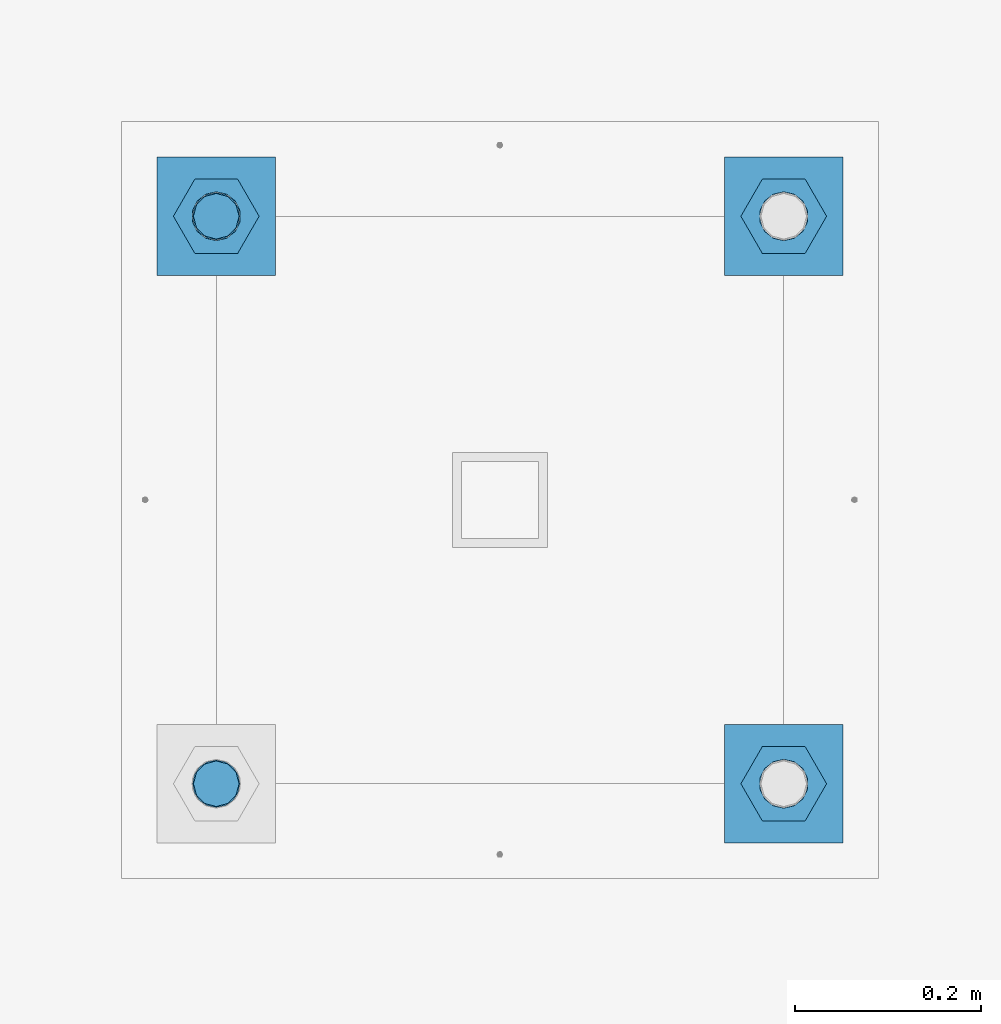
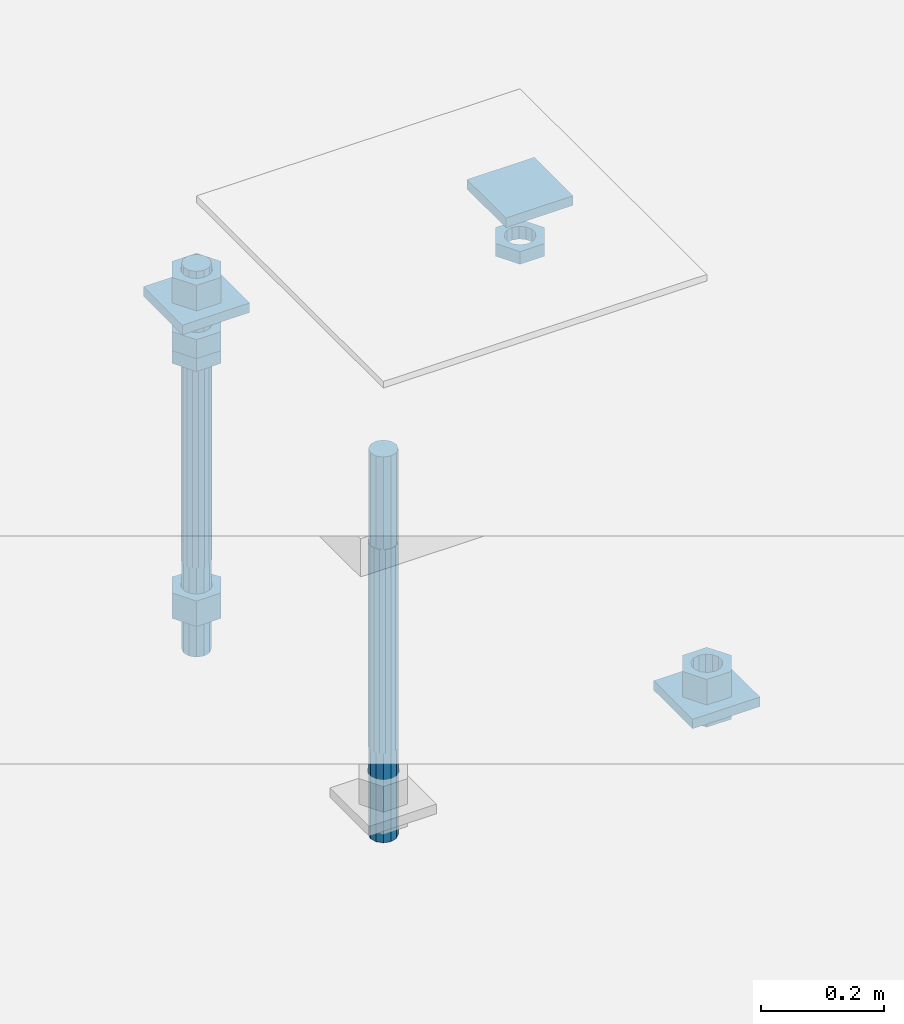
# One storey, part 2707 of 3843: 12 beams, 1 element without a shape of its own.
"""IFC2X3 building model written with IfcOpenShell, lengths in millimetres."""

from ifc_helpers import new_model, si_unit, frame, origin_with_axes, place, context, subcontext, project, spatial, faceted_brep, material, type_object, element, aggregate, save


model = new_model("IFC2X3")

# Units and contexts
model_context = context("Model", 3, precision=1e-05, world=origin_with_axes())
body_context = subcontext(model_context, "Body", "Model", "MODEL_VIEW")
ifc_project = project(units=[si_unit("LENGTHUNIT", "METRE", prefix="MILLI"), si_unit("AREAUNIT", "SQUARE_METRE"), si_unit("VOLUMEUNIT", "CUBIC_METRE"), si_unit("MASSUNIT", "GRAM", prefix="KILO"), si_unit("TIMEUNIT", "SECOND"), si_unit("PLANEANGLEUNIT", "RADIAN"), si_unit("SOLIDANGLEUNIT", "STERADIAN"), si_unit("THERMODYNAMICTEMPERATUREUNIT", "DEGREE_CELSIUS"), si_unit("LUMINOUSINTENSITYUNIT", "LUMEN")], contexts=[model_context])

# Site, building, storey
site_placement = place(None, origin_with_axes())
site = spatial("IfcSite", under=ifc_project, at=site_placement, CompositionType="ELEMENT")
building_placement = place(site_placement, origin_with_axes())
building = spatial("IfcBuilding", under=site, at=building_placement, Name="Undefined", CompositionType="ELEMENT")
storey_placement = place(building_placement, origin_with_axes())
storey = spatial("IfcBuildingStorey", under=building, at=storey_placement, Name="Undefined", CompositionType="ELEMENT", Elevation=0.0)

# Assembly, beams
assembly_placement = place(storey_placement, origin_with_axes())
assembly = element("IfcElementAssembly", 1, at=assembly_placement, inside=storey, Name="TEMPLATE", AssemblyPlace="NOTDEFINED", PredefinedType="RIGID_FRAME")
ifc_material_1 = material(Name="STEEL/A36")
beam_type_1 = type_object("IfcBeamType", PredefinedType="NOTDEFINED")
beam_1_placement = place(assembly_placement, frame((108648.5, 45808.9000015259, 29873.575), z_axis=(1.0, 0.0, 0.0), x_axis=(0.0, 1.0, 0.0)))
beam_1 = element("IfcBeam", 2, at=beam_1_placement, type_object=beam_type_1, material=ifc_material_1, Name="WASHER_PLATE", context=body_context, shape_type="Brep", body=[
    faceted_brep([(0.0, 9.52500000000146, -63.5), (0.0, 9.52500000000146, 63.5), (127.0, 9.52500000000146, 63.5), (127.0, 9.52500000000146, -63.5), (0.0, -9.52500000000146, 63.5), (127.0, -9.52500000000146, 63.5), (0.0, -9.52500000000146, -63.5), (127.0, -9.52500000000146, -63.5)], [[[0, 1, 2, 3]], [[1, 4, 5, 2]], [[4, 6, 7, 5]], [[6, 0, 3, 7]], [[5, 7, 3, 2]], [[6, 4, 1, 0]]]),
])
beam_2_placement = place(assembly_placement, frame((109258.1, 45808.9000015259, 29873.575), z_axis=(1.0, 0.0, 0.0), x_axis=(0.0, 1.0, 0.0)))
beam_2 = element("IfcBeam", 3, at=beam_2_placement, type_object=beam_type_1, material=ifc_material_1, Name="WASHER_PLATE", context=body_context, shape_type="Brep", body=[
    faceted_brep([(0.0, 9.52500000000146, -63.5), (0.0, 9.52500000000146, 63.5), (127.0, 9.52500000000146, 63.5), (127.0, 9.52500000000146, -63.5), (0.0, -9.52500000000146, 63.5), (127.0, -9.52500000000146, 63.5), (0.0, -9.52500000000146, -63.5), (127.0, -9.52500000000146, -63.5)], [[[0, 1, 2, 3]], [[1, 4, 5, 2]], [[4, 6, 7, 5]], [[6, 0, 3, 7]], [[5, 7, 3, 2]], [[6, 4, 1, 0]]]),
])
beam_3_placement = place(assembly_placement, frame((109258.1, 45199.3000015259, 29244.925), z_axis=(1.0, 0.0, 0.0), x_axis=(0.0, 1.0, 0.0)))
beam_3 = element("IfcBeam", 4, at=beam_3_placement, type_object=beam_type_1, material=ifc_material_1, Name="WASHER_PLATE", context=body_context, shape_type="Brep", body=[
    faceted_brep([(0.0, 9.52500000000146, -63.5), (0.0, 9.52500000000146, 63.5), (127.0, 9.52500000000146, 63.5), (127.0, 9.52500000000146, -63.5), (0.0, -9.52500000000146, 63.5), (127.0, -9.52500000000146, 63.5), (0.0, -9.52500000000146, -63.5), (127.0, -9.52500000000146, -63.5)], [[[0, 1, 2, 3]], [[1, 4, 5, 2]], [[4, 6, 7, 5]], [[6, 0, 3, 7]], [[5, 7, 3, 2]], [[6, 4, 1, 0]]]),
])
beam_type_2 = type_object("IfcBeamType", Name="2_HALF_NUT", PredefinedType="NOTDEFINED")
beam_4_placement = place(assembly_placement, frame((108648.5, 45872.4000015259, 29787.85), z_axis=(0.0, 1.0, 0.0), x_axis=(0.0, 0.0, -1.0)))
beam_4 = element("IfcBeam", 5, at=beam_4_placement, type_object=beam_type_2, material=ifc_material_1, Name="NUT", ObjectType="2_HALF_NUT", context=body_context, shape_type="Brep", body=[
    faceted_brep([(0.0, -46.0369987487793, 0.0), (0.0, -23.0184993743896, -39.869213104248), (25.4000000000015, -23.0184993743896, -39.869213104248), (25.4000000000015, -46.0369987487793, 0.0), (0.0, 23.0184993743896, -39.869213104248), (25.4000000000015, 23.0184993743896, -39.869213104248), (0.0, 46.0369987487793, 0.0), (25.4000000000015, 46.0369987487793, 0.0), (0.0, 23.0184993743896, 39.869213104248), (25.4000000000015, 23.0184993743896, 39.869213104248), (0.0, -23.0184993743896, 39.869213104248), (25.4000000000015, -23.0184993743896, 39.869213104248), (0.0, 0.0, 26.1940002441406), (0.0, 11.3650617044477, 23.5999013092805), (25.4000000000015, 11.3650617044477, 23.5999013092805), (25.4000000000015, 0.0, 26.1940002441406), (0.0, 20.4791109456419, 16.3316083006721), (25.4000000000015, 20.4791109456419, 16.3316083006721), (0.0, 25.5370200498292, 5.82867859874386), (25.4000000000015, 25.5370200498292, 5.82867859874386), (0.0, 25.5370200498292, -5.82867859874386), (25.4000000000015, 25.5370200498292, -5.82867859874386), (0.0, 20.4791109456419, -16.3316083006721), (25.4000000000015, 20.4791109456419, -16.3316083006721), (0.0, 11.3650617044477, -23.5999013092805), (25.4000000000015, 11.3650617044477, -23.5999013092805), (0.0, 0.0, -26.1940002441406), (25.4000000000015, 0.0, -26.1940002441406), (0.0, -11.3650617044477, -23.5999013092805), (25.4000000000015, -11.3650617044477, -23.5999013092805), (0.0, -20.4791109456419, -16.3316083006721), (25.4000000000015, -20.4791109456419, -16.3316083006721), (0.0, -25.5370200498292, -5.82867859874386), (25.4000000000015, -25.5370200498292, -5.82867859874386), (0.0, -25.5370200498292, 5.82867859874386), (25.4000000000015, -25.5370200498292, 5.82867859874386), (0.0, -20.4791109456419, 16.3316083006721), (25.4000000000015, -20.4791109456419, 16.3316083006721), (0.0, -11.3650617044477, 23.5999013092805), (25.4000000000015, -11.3650617044477, 23.5999013092805)], [[[0, 1, 2, 3]], [[1, 4, 5, 2]], [[4, 6, 7, 5]], [[6, 8, 9, 7]], [[8, 10, 11, 9]], [[10, 0, 3, 11]], [[12, 13, 14, 15]], [[13, 16, 17, 14]], [[16, 18, 19, 17]], [[18, 20, 21, 19]], [[20, 22, 23, 21]], [[22, 24, 25, 23]], [[24, 26, 27, 25]], [[26, 28, 29, 27]], [[28, 30, 31, 29]], [[30, 32, 33, 31]], [[32, 34, 35, 33]], [[34, 36, 37, 35]], [[36, 38, 39, 37]], [[38, 12, 15, 39]], [[5, 7, 9, 11, 3, 2], [17, 19, 21, 23, 25, 27, 29, 31, 33, 35, 37, 39, 15, 14]], [[10, 8, 6, 4, 1, 0], [38, 36, 34, 32, 30, 28, 26, 24, 22, 20, 18, 16, 13, 12]]]),
])
beam_5_placement = place(assembly_placement, frame((109258.1, 45872.4000015259, 29787.85), z_axis=(0.0, 1.0, 0.0), x_axis=(0.0, 0.0, -1.0)))
beam_5 = element("IfcBeam", 6, at=beam_5_placement, type_object=beam_type_2, material=ifc_material_1, Name="NUT", ObjectType="2_HALF_NUT", context=body_context, shape_type="Brep", body=[
    faceted_brep([(0.0, -46.0369987487793, 0.0), (0.0, -23.0184993743896, -39.869213104248), (25.4000000000015, -23.0184993743896, -39.869213104248), (25.4000000000015, -46.0369987487793, 0.0), (0.0, 23.0184993743896, -39.869213104248), (25.4000000000015, 23.0184993743896, -39.869213104248), (0.0, 46.0369987487793, 0.0), (25.4000000000015, 46.0369987487793, 0.0), (0.0, 23.0184993743896, 39.869213104248), (25.4000000000015, 23.0184993743896, 39.869213104248), (0.0, -23.0184993743896, 39.869213104248), (25.4000000000015, -23.0184993743896, 39.869213104248), (0.0, 0.0, 26.1940002441406), (0.0, 11.3650617044477, 23.5999013092805), (25.4000000000015, 11.3650617044477, 23.5999013092805), (25.4000000000015, 0.0, 26.1940002441406), (0.0, 20.4791109456419, 16.3316083006721), (25.4000000000015, 20.4791109456419, 16.3316083006721), (0.0, 25.5370200498292, 5.82867859874386), (25.4000000000015, 25.5370200498292, 5.82867859874386), (0.0, 25.5370200498292, -5.82867859874386), (25.4000000000015, 25.5370200498292, -5.82867859874386), (0.0, 20.4791109456419, -16.3316083006721), (25.4000000000015, 20.4791109456419, -16.3316083006721), (0.0, 11.3650617044477, -23.5999013092805), (25.4000000000015, 11.3650617044477, -23.5999013092805), (0.0, 0.0, -26.1940002441406), (25.4000000000015, 0.0, -26.1940002441406), (0.0, -11.3650617044477, -23.5999013092805), (25.4000000000015, -11.3650617044477, -23.5999013092805), (0.0, -20.4791109456419, -16.3316083006721), (25.4000000000015, -20.4791109456419, -16.3316083006721), (0.0, -25.5370200498292, -5.82867859874386), (25.4000000000015, -25.5370200498292, -5.82867859874386), (0.0, -25.5370200498292, 5.82867859874386), (25.4000000000015, -25.5370200498292, 5.82867859874386), (0.0, -20.4791109456419, 16.3316083006721), (25.4000000000015, -20.4791109456419, 16.3316083006721), (0.0, -11.3650617044477, 23.5999013092805), (25.4000000000015, -11.3650617044477, 23.5999013092805)], [[[0, 1, 2, 3]], [[1, 4, 5, 2]], [[4, 6, 7, 5]], [[6, 8, 9, 7]], [[8, 10, 11, 9]], [[10, 0, 3, 11]], [[12, 13, 14, 15]], [[13, 16, 17, 14]], [[16, 18, 19, 17]], [[18, 20, 21, 19]], [[20, 22, 23, 21]], [[22, 24, 25, 23]], [[24, 26, 27, 25]], [[26, 28, 29, 27]], [[28, 30, 31, 29]], [[30, 32, 33, 31]], [[32, 34, 35, 33]], [[34, 36, 37, 35]], [[36, 38, 39, 37]], [[38, 12, 15, 39]], [[5, 7, 9, 11, 3, 2], [17, 19, 21, 23, 25, 27, 29, 31, 33, 35, 37, 39, 15, 14]], [[10, 8, 6, 4, 1, 0], [38, 36, 34, 32, 30, 28, 26, 24, 22, 20, 18, 16, 13, 12]]]),
])
beam_6_placement = place(assembly_placement, frame((109258.1, 45262.8000015259, 29235.4), z_axis=(0.0, 1.0, 0.0), x_axis=(0.0, 0.0, -1.0)))
beam_6 = element("IfcBeam", 7, at=beam_6_placement, type_object=beam_type_2, material=ifc_material_1, Name="NUT", ObjectType="2_HALF_NUT", context=body_context, shape_type="Brep", body=[
    faceted_brep([(0.0, -46.0369987487793, 0.0), (0.0, -23.0184993743896, -39.869213104248), (25.4000000000015, -23.0184993743896, -39.869213104248), (25.4000000000015, -46.0369987487793, 0.0), (0.0, 23.0184993743896, -39.869213104248), (25.4000000000015, 23.0184993743896, -39.869213104248), (0.0, 46.0369987487793, 0.0), (25.4000000000015, 46.0369987487793, 0.0), (0.0, 23.0184993743896, 39.869213104248), (25.4000000000015, 23.0184993743896, 39.869213104248), (0.0, -23.0184993743896, 39.869213104248), (25.4000000000015, -23.0184993743896, 39.869213104248), (0.0, 0.0, 26.1940002441406), (0.0, 11.3650617044477, 23.5999013092805), (25.4000000000015, 11.3650617044477, 23.5999013092805), (25.4000000000015, 0.0, 26.1940002441406), (0.0, 20.4791109456419, 16.3316083006721), (25.4000000000015, 20.4791109456419, 16.3316083006721), (0.0, 25.5370200498292, 5.82867859874386), (25.4000000000015, 25.5370200498292, 5.82867859874386), (0.0, 25.5370200498292, -5.82867859874386), (25.4000000000015, 25.5370200498292, -5.82867859874386), (0.0, 20.4791109456419, -16.3316083006721), (25.4000000000015, 20.4791109456419, -16.3316083006721), (0.0, 11.3650617044477, -23.5999013092805), (25.4000000000015, 11.3650617044477, -23.5999013092805), (0.0, 0.0, -26.1940002441406), (25.4000000000015, 0.0, -26.1940002441406), (0.0, -11.3650617044477, -23.5999013092805), (25.4000000000015, -11.3650617044477, -23.5999013092805), (0.0, -20.4791109456419, -16.3316083006721), (25.4000000000015, -20.4791109456419, -16.3316083006721), (0.0, -25.5370200498292, -5.82867859874386), (25.4000000000015, -25.5370200498292, -5.82867859874386), (0.0, -25.5370200498292, 5.82867859874386), (25.4000000000015, -25.5370200498292, 5.82867859874386), (0.0, -20.4791109456419, 16.3316083006721), (25.4000000000015, -20.4791109456419, 16.3316083006721), (0.0, -11.3650617044477, 23.5999013092805), (25.4000000000015, -11.3650617044477, 23.5999013092805)], [[[0, 1, 2, 3]], [[1, 4, 5, 2]], [[4, 6, 7, 5]], [[6, 8, 9, 7]], [[8, 10, 11, 9]], [[10, 0, 3, 11]], [[12, 13, 14, 15]], [[13, 16, 17, 14]], [[16, 18, 19, 17]], [[18, 20, 21, 19]], [[20, 22, 23, 21]], [[22, 24, 25, 23]], [[24, 26, 27, 25]], [[26, 28, 29, 27]], [[28, 30, 31, 29]], [[30, 32, 33, 31]], [[32, 34, 35, 33]], [[34, 36, 37, 35]], [[36, 38, 39, 37]], [[38, 12, 15, 39]], [[5, 7, 9, 11, 3, 2], [17, 19, 21, 23, 25, 27, 29, 31, 33, 35, 37, 39, 15, 14]], [[10, 8, 6, 4, 1, 0], [38, 36, 34, 32, 30, 28, 26, 24, 22, 20, 18, 16, 13, 12]]]),
])
beam_type_3 = type_object("IfcBeamType", Name="2_HEAVY_HEX_NUT", PredefinedType="NOTDEFINED")
beam_7_placement = place(assembly_placement, frame((109258.1, 45262.8000015259, 29305.25), z_axis=(0.0, 1.0, 0.0), x_axis=(0.0, 0.0, -1.0)))
beam_7 = element("IfcBeam", 8, at=beam_7_placement, type_object=beam_type_3, material=ifc_material_1, Name="NUT", ObjectType="2_HEAVY_HEX_NUT", context=body_context, shape_type="Brep", body=[
    faceted_brep([(0.0, -46.0369987487793, 0.0), (0.0, -23.0184993743896, -39.869213104248), (50.7999999999993, -23.0184993743896, -39.869213104248), (50.7999999999993, -46.0369987487793, 0.0), (0.0, 23.0184993743896, -39.869213104248), (50.7999999999993, 23.0184993743896, -39.869213104248), (0.0, 46.0369987487793, 0.0), (50.7999999999993, 46.0369987487793, 0.0), (0.0, 23.0184993743896, 39.869213104248), (50.7999999999993, 23.0184993743896, 39.869213104248), (0.0, -23.0184993743896, 39.869213104248), (50.7999999999993, -23.0184993743896, 39.869213104248), (0.0, 0.0, 26.1940002441406), (0.0, 11.3650617044477, 23.5999013092805), (50.7999999999993, 11.3650617044477, 23.5999013092805), (50.7999999999993, 0.0, 26.1940002441406), (0.0, 20.4791109456419, 16.3316083006721), (50.7999999999993, 20.4791109456419, 16.3316083006721), (0.0, 25.5370200498292, 5.82867859874386), (50.7999999999993, 25.5370200498292, 5.82867859874386), (0.0, 25.5370200498292, -5.82867859874386), (50.7999999999993, 25.5370200498292, -5.82867859874386), (0.0, 20.4791109456419, -16.3316083006721), (50.7999999999993, 20.4791109456419, -16.3316083006721), (0.0, 11.3650617044477, -23.5999013092805), (50.7999999999993, 11.3650617044477, -23.5999013092805), (0.0, 0.0, -26.1940002441406), (50.7999999999993, 0.0, -26.1940002441406), (0.0, -11.3650617044477, -23.5999013092805), (50.7999999999993, -11.3650617044477, -23.5999013092805), (0.0, -20.4791109456419, -16.3316083006721), (50.7999999999993, -20.4791109456419, -16.3316083006721), (0.0, -25.5370200498292, -5.82867859874386), (50.7999999999993, -25.5370200498292, -5.82867859874386), (0.0, -25.5370200498292, 5.82867859874386), (50.7999999999993, -25.5370200498292, 5.82867859874386), (0.0, -20.4791109456419, 16.3316083006721), (50.7999999999993, -20.4791109456419, 16.3316083006721), (0.0, -11.3650617044477, 23.5999013092805), (50.7999999999993, -11.3650617044477, 23.5999013092805)], [[[0, 1, 2, 3]], [[1, 4, 5, 2]], [[4, 6, 7, 5]], [[6, 8, 9, 7]], [[8, 10, 11, 9]], [[10, 0, 3, 11]], [[12, 13, 14, 15]], [[13, 16, 17, 14]], [[16, 18, 19, 17]], [[18, 20, 21, 19]], [[20, 22, 23, 21]], [[22, 24, 25, 23]], [[24, 26, 27, 25]], [[26, 28, 29, 27]], [[28, 30, 31, 29]], [[30, 32, 33, 31]], [[32, 34, 35, 33]], [[34, 36, 37, 35]], [[36, 38, 39, 37]], [[38, 12, 15, 39]], [[5, 7, 9, 11, 3, 2], [17, 19, 21, 23, 25, 27, 29, 31, 33, 35, 37, 39, 15, 14]], [[10, 8, 6, 4, 1, 0], [38, 36, 34, 32, 30, 28, 26, 24, 22, 20, 18, 16, 13, 12]]]),
])
beam_8_placement = place(assembly_placement, frame((108648.5, 45872.4000015259, 29825.95), z_axis=(0.0, 1.0, 0.0), x_axis=(0.0, 0.0, -1.0)))
beam_8 = element("IfcBeam", 9, at=beam_8_placement, type_object=beam_type_3, material=ifc_material_1, Name="NUT", ObjectType="2_HEAVY_HEX_NUT", context=body_context, shape_type="Brep", body=[
    faceted_brep([(0.0, -46.0369987487793, 0.0), (0.0, -23.0184993743896, -39.869213104248), (38.0999999999985, -23.0184993743896, -39.869213104248), (38.0999999999985, -46.0369987487793, 0.0), (0.0, 23.0184993743896, -39.869213104248), (38.0999999999985, 23.0184993743896, -39.869213104248), (0.0, 46.0369987487793, 0.0), (38.0999999999985, 46.0369987487793, 0.0), (0.0, 23.0184993743896, 39.869213104248), (38.0999999999985, 23.0184993743896, 39.869213104248), (0.0, -23.0184993743896, 39.869213104248), (38.0999999999985, -23.0184993743896, 39.869213104248), (0.0, 0.0, 26.1940002441406), (0.0, 11.3650617044477, 23.5999013092805), (38.0999999999985, 11.3650617044477, 23.5999013092805), (38.0999999999985, 0.0, 26.1940002441406), (0.0, 20.4791109456419, 16.3316083006721), (38.0999999999985, 20.4791109456419, 16.3316083006721), (0.0, 25.5370200498292, 5.82867859874386), (38.0999999999985, 25.5370200498292, 5.82867859874386), (0.0, 25.5370200498292, -5.82867859874386), (38.0999999999985, 25.5370200498292, -5.82867859874386), (0.0, 20.4791109456419, -16.3316083006721), (38.0999999999985, 20.4791109456419, -16.3316083006721), (0.0, 11.3650617044477, -23.5999013092805), (38.0999999999985, 11.3650617044477, -23.5999013092805), (0.0, 0.0, -26.1940002441406), (38.0999999999985, 0.0, -26.1940002441406), (0.0, -11.3650617044477, -23.5999013092805), (38.0999999999985, -11.3650617044477, -23.5999013092805), (0.0, -20.4791109456419, -16.3316083006721), (38.0999999999985, -20.4791109456419, -16.3316083006721), (0.0, -25.5370200498292, -5.82867859874386), (38.0999999999985, -25.5370200498292, -5.82867859874386), (0.0, -25.5370200498292, 5.82867859874386), (38.0999999999985, -25.5370200498292, 5.82867859874386), (0.0, -20.4791109456419, 16.3316083006721), (38.0999999999985, -20.4791109456419, 16.3316083006721), (0.0, -11.3650617044477, 23.5999013092805), (38.0999999999985, -11.3650617044477, 23.5999013092805)], [[[0, 1, 2, 3]], [[1, 4, 5, 2]], [[4, 6, 7, 5]], [[6, 8, 9, 7]], [[8, 10, 11, 9]], [[10, 0, 3, 11]], [[12, 13, 14, 15]], [[13, 16, 17, 14]], [[16, 18, 19, 17]], [[18, 20, 21, 19]], [[20, 22, 23, 21]], [[22, 24, 25, 23]], [[24, 26, 27, 25]], [[26, 28, 29, 27]], [[28, 30, 31, 29]], [[30, 32, 33, 31]], [[32, 34, 35, 33]], [[34, 36, 37, 35]], [[36, 38, 39, 37]], [[38, 12, 15, 39]], [[5, 7, 9, 11, 3, 2], [17, 19, 21, 23, 25, 27, 29, 31, 33, 35, 37, 39, 15, 14]], [[10, 8, 6, 4, 1, 0], [38, 36, 34, 32, 30, 28, 26, 24, 22, 20, 18, 16, 13, 12]]]),
])
beam_9_placement = place(assembly_placement, frame((108648.5, 45872.4000015259, 29933.9), z_axis=(0.0, 1.0, 0.0), x_axis=(0.0, 0.0, -1.0)))
beam_9 = element("IfcBeam", 10, at=beam_9_placement, type_object=beam_type_3, material=ifc_material_1, Name="NUT", ObjectType="2_HEAVY_HEX_NUT", context=body_context, shape_type="Brep", body=[
    faceted_brep([(0.0, -46.0369987487793, 0.0), (0.0, -23.0184993743896, -39.869213104248), (50.7999999999993, -23.0184993743896, -39.869213104248), (50.7999999999993, -46.0369987487793, 0.0), (0.0, 23.0184993743896, -39.869213104248), (50.7999999999993, 23.0184993743896, -39.869213104248), (0.0, 46.0369987487793, 0.0), (50.7999999999993, 46.0369987487793, 0.0), (0.0, 23.0184993743896, 39.869213104248), (50.7999999999993, 23.0184993743896, 39.869213104248), (0.0, -23.0184993743896, 39.869213104248), (50.7999999999993, -23.0184993743896, 39.869213104248), (0.0, 0.0, 26.1940002441406), (0.0, 11.3650617044477, 23.5999013092805), (50.7999999999993, 11.3650617044477, 23.5999013092805), (50.7999999999993, 0.0, 26.1940002441406), (0.0, 20.4791109456419, 16.3316083006721), (50.7999999999993, 20.4791109456419, 16.3316083006721), (0.0, 25.5370200498292, 5.82867859874386), (50.7999999999993, 25.5370200498292, 5.82867859874386), (0.0, 25.5370200498292, -5.82867859874386), (50.7999999999993, 25.5370200498292, -5.82867859874386), (0.0, 20.4791109456419, -16.3316083006721), (50.7999999999993, 20.4791109456419, -16.3316083006721), (0.0, 11.3650617044477, -23.5999013092805), (50.7999999999993, 11.3650617044477, -23.5999013092805), (0.0, 0.0, -26.1940002441406), (50.7999999999993, 0.0, -26.1940002441406), (0.0, -11.3650617044477, -23.5999013092805), (50.7999999999993, -11.3650617044477, -23.5999013092805), (0.0, -20.4791109456419, -16.3316083006721), (50.7999999999993, -20.4791109456419, -16.3316083006721), (0.0, -25.5370200498292, -5.82867859874386), (50.7999999999993, -25.5370200498292, -5.82867859874386), (0.0, -25.5370200498292, 5.82867859874386), (50.7999999999993, -25.5370200498292, 5.82867859874386), (0.0, -20.4791109456419, 16.3316083006721), (50.7999999999993, -20.4791109456419, 16.3316083006721), (0.0, -11.3650617044477, 23.5999013092805), (50.7999999999993, -11.3650617044477, 23.5999013092805)], [[[0, 1, 2, 3]], [[1, 4, 5, 2]], [[4, 6, 7, 5]], [[6, 8, 9, 7]], [[8, 10, 11, 9]], [[10, 0, 3, 11]], [[12, 13, 14, 15]], [[13, 16, 17, 14]], [[16, 18, 19, 17]], [[18, 20, 21, 19]], [[20, 22, 23, 21]], [[22, 24, 25, 23]], [[24, 26, 27, 25]], [[26, 28, 29, 27]], [[28, 30, 31, 29]], [[30, 32, 33, 31]], [[32, 34, 35, 33]], [[34, 36, 37, 35]], [[36, 38, 39, 37]], [[38, 12, 15, 39]], [[5, 7, 9, 11, 3, 2], [17, 19, 21, 23, 25, 27, 29, 31, 33, 35, 37, 39, 15, 14]], [[10, 8, 6, 4, 1, 0], [38, 36, 34, 32, 30, 28, 26, 24, 22, 20, 18, 16, 13, 12]]]),
])
beam_10_placement = place(assembly_placement, frame((108648.5, 45872.4000015259, 29305.25), z_axis=(0.0, 1.0, 0.0), x_axis=(0.0, 0.0, -1.0)))
beam_10 = element("IfcBeam", 11, at=beam_10_placement, type_object=beam_type_3, material=ifc_material_1, Name="NUT", ObjectType="2_HEAVY_HEX_NUT", context=body_context, shape_type="Brep", body=[
    faceted_brep([(0.0, -46.0369987487793, 0.0), (0.0, -23.0184993743896, -39.869213104248), (50.7999999999993, -23.0184993743896, -39.869213104248), (50.7999999999993, -46.0369987487793, 0.0), (0.0, 23.0184993743896, -39.869213104248), (50.7999999999993, 23.0184993743896, -39.869213104248), (0.0, 46.0369987487793, 0.0), (50.7999999999993, 46.0369987487793, 0.0), (0.0, 23.0184993743896, 39.869213104248), (50.7999999999993, 23.0184993743896, 39.869213104248), (0.0, -23.0184993743896, 39.869213104248), (50.7999999999993, -23.0184993743896, 39.869213104248), (0.0, 0.0, 26.1940002441406), (0.0, 11.3650617044477, 23.5999013092805), (50.7999999999993, 11.3650617044477, 23.5999013092805), (50.7999999999993, 0.0, 26.1940002441406), (0.0, 20.4791109456419, 16.3316083006721), (50.7999999999993, 20.4791109456419, 16.3316083006721), (0.0, 25.5370200498292, 5.82867859874386), (50.7999999999993, 25.5370200498292, 5.82867859874386), (0.0, 25.5370200498292, -5.82867859874386), (50.7999999999993, 25.5370200498292, -5.82867859874386), (0.0, 20.4791109456419, -16.3316083006721), (50.7999999999993, 20.4791109456419, -16.3316083006721), (0.0, 11.3650617044477, -23.5999013092805), (50.7999999999993, 11.3650617044477, -23.5999013092805), (0.0, 0.0, -26.1940002441406), (50.7999999999993, 0.0, -26.1940002441406), (0.0, -11.3650617044477, -23.5999013092805), (50.7999999999993, -11.3650617044477, -23.5999013092805), (0.0, -20.4791109456419, -16.3316083006721), (50.7999999999993, -20.4791109456419, -16.3316083006721), (0.0, -25.5370200498292, -5.82867859874386), (50.7999999999993, -25.5370200498292, -5.82867859874386), (0.0, -25.5370200498292, 5.82867859874386), (50.7999999999993, -25.5370200498292, 5.82867859874386), (0.0, -20.4791109456419, 16.3316083006721), (50.7999999999993, -20.4791109456419, 16.3316083006721), (0.0, -11.3650617044477, 23.5999013092805), (50.7999999999993, -11.3650617044477, 23.5999013092805)], [[[0, 1, 2, 3]], [[1, 4, 5, 2]], [[4, 6, 7, 5]], [[6, 8, 9, 7]], [[8, 10, 11, 9]], [[10, 0, 3, 11]], [[12, 13, 14, 15]], [[13, 16, 17, 14]], [[16, 18, 19, 17]], [[18, 20, 21, 19]], [[20, 22, 23, 21]], [[22, 24, 25, 23]], [[24, 26, 27, 25]], [[26, 28, 29, 27]], [[28, 30, 31, 29]], [[30, 32, 33, 31]], [[32, 34, 35, 33]], [[34, 36, 37, 35]], [[36, 38, 39, 37]], [[38, 12, 15, 39]], [[5, 7, 9, 11, 3, 2], [17, 19, 21, 23, 25, 27, 29, 31, 33, 35, 37, 39, 15, 14]], [[10, 8, 6, 4, 1, 0], [38, 36, 34, 32, 30, 28, 26, 24, 22, 20, 18, 16, 13, 12]]]),
])
ifc_material_2 = material()
beam_type_4 = type_object("IfcBeamType", PredefinedType="NOTDEFINED")
beam_11_placement = place(assembly_placement, frame((108648.5, 45872.4000015259, 29762.45), z_axis=(0.0, 1.0, 0.0), x_axis=(0.0, 0.0, -1.0)))
beam_11 = element("IfcBeam", 12, at=beam_11_placement, type_object=beam_type_4, material=ifc_material_2, Name="ANCHOR_ROD", context=body_context, shape_type="Brep", body=[
    faceted_brep([(-184.150000000001, -21.217622392709, 12.25), (-184.150000000001, -12.2499999999854, 21.2176223927163), (-184.150000000001, 1.45519152283669e-11, 24.5), (-184.150000000001, 12.2500000000146, 21.2176223927163), (-184.150000000001, 21.2176223927381, 12.25), (-184.150000000001, 24.5000000000146, 0.0), (-184.150000000001, 21.2176223927381, -12.25), (-184.150000000001, 12.2500000000146, -21.2176223927163), (-184.150000000001, 1.45519152283669e-11, -24.5), (-184.150000000001, -12.2499999999854, -21.2176223927163), (-184.150000000001, -21.217622392709, -12.25), (-184.150000000001, -24.4999999999854, 0.0), (0.0, 24.5000000000146, 0.0), (0.0, 21.2176223927381, -12.25), (0.0, 12.2500000000146, -21.2176223927163), (0.0, 1.45519152283669e-11, -24.5), (0.0, -12.2499999999854, -21.2176223927163), (0.0, -21.217622392709, -12.25), (0.0, -24.4999999999854, 0.0), (0.0, -21.217622392709, 12.25), (0.0, -12.2499999999854, 21.2176223927163), (0.0, 1.45519152283669e-11, 24.5), (0.0, 12.2500000000146, 21.2176223927163), (0.0, 21.2176223927381, 12.25), (0.0, -23.4665401257807, 9.72015918207035), (0.0, -17.9605122421344, 17.9605122421417), (0.0, -9.72015918207762, 23.466540125788), (0.0, 0.0, 25.4000000000015), (0.0, 9.72015918207762, 23.466540125788), (0.0, 17.9605122421344, 17.9605122421417), (0.0, 23.4665401257807, 9.72015918207035), (0.0, 25.3999996185303, 0.0), (0.0, 23.4665401257807, -9.72015918207035), (0.0, 17.9605122421344, -17.9605122421417), (0.0, 9.72015918207762, -23.466540125788), (0.0, 0.0, -25.4000000000015), (0.0, -9.72015918207762, -23.466540125788), (0.0, -17.9605122421344, -17.9605122421417), (0.0, -23.4665401257807, -9.72015918207035), (0.0, -25.3999996185303, 0.0), (406.399999999998, -25.3999999999942, 0.0), (406.399999999998, -23.4665401257807, 9.72015918207035), (406.399999999998, -17.9605122421344, 17.9605122421417), (406.399999999998, -9.72015918207762, 23.466540125788), (406.399999999998, 0.0, 25.4000000000015), (406.399999999998, 9.72015918207762, 23.466540125788), (406.399999999998, 17.9605122421344, 17.9605122421417), (406.399999999998, 23.4665401257807, 9.72015918207035), (406.399999999998, 25.3999999999942, 0.0), (406.399999999998, 23.4665401257807, -9.72015918207035), (406.399999999998, 17.9605122421344, -17.9605122421417), (406.399999999998, 9.72015918207762, -23.466540125788), (406.399999999998, 0.0, -25.4000000000015), (406.399999999998, -9.72015918207762, -23.466540125788), (406.399999999998, -17.9605122421344, -17.9605122421417), (406.399999999998, -23.4665401257807, -9.72015918207035), (406.399999999998, -12.2499999999854, 21.2176223927163), (406.399999999998, 1.45519152283669e-11, 24.5), (406.399999999998, 12.2500000000146, 21.2176223927163), (406.399999999998, 21.2176223927381, 12.25), (406.399999999998, 24.5000000000146, 0.0), (406.399999999998, 21.2176223927381, -12.25), (406.399999999998, 12.2500000000146, -21.2176223927163), (406.399999999998, 1.45519152283669e-11, -24.5), (406.399999999998, -12.2499999999854, -21.2176223927163), (406.399999999998, -21.217622392709, -12.25), (406.399999999998, -24.4999999999854, 0.0), (406.399999999998, -21.217622392709, 12.25), (584.200000000001, -12.2499999999854, -21.2176223927163), (584.200000000001, 1.45519152283669e-11, -24.5), (584.200000000001, 12.2500000000146, -21.2176223927163), (584.200000000001, 21.2176223927381, -12.25), (584.200000000001, 24.5000000000146, 0.0), (584.200000000001, 21.2176223927381, 12.25), (584.200000000001, 12.2500000000146, 21.2176223927163), (584.200000000001, 1.45519152283669e-11, 24.5), (584.200000000001, -12.2499999999854, 21.2176223927163), (584.200000000001, -21.217622392709, 12.25), (584.200000000001, -24.4999999999854, 0.0), (584.200000000001, -21.217622392709, -12.25)], [[[0, 1, 2, 3, 4, 5, 6, 7, 8, 9, 10, 11]], [[6, 5, 12, 13]], [[7, 6, 13, 14]], [[8, 7, 14, 15]], [[9, 8, 15, 16]], [[10, 9, 16, 17]], [[11, 10, 17, 18]], [[0, 11, 18, 19]], [[1, 0, 19, 20]], [[2, 1, 20, 21]], [[3, 2, 21, 22]], [[4, 3, 22, 23]], [[5, 4, 23, 12]], [[24, 25, 26, 27, 28, 29, 30, 31, 32, 33, 34, 35, 36, 37, 38, 39], [22, 21, 20, 19, 18, 17, 16, 15, 14, 13, 12, 23]], [[24, 39, 40, 41]], [[25, 24, 41, 42]], [[26, 25, 42, 43]], [[27, 26, 43, 44]], [[28, 27, 44, 45]], [[29, 28, 45, 46]], [[30, 29, 46, 47]], [[31, 30, 47, 48]], [[32, 31, 48, 49]], [[33, 32, 49, 50]], [[34, 33, 50, 51]], [[35, 34, 51, 52]], [[36, 35, 52, 53]], [[37, 36, 53, 54]], [[38, 37, 54, 55]], [[39, 38, 55, 40]], [[54, 53, 52, 51, 50, 49, 48, 47, 46, 45, 44, 43, 42, 41, 40, 55], [56, 57, 58, 59, 60, 61, 62, 63, 64, 65, 66, 67]], [[68, 69, 70, 71, 72, 73, 74, 75, 76, 77, 78, 79]], [[76, 75, 57, 56]], [[77, 76, 56, 67]], [[78, 77, 67, 66]], [[79, 78, 66, 65]], [[68, 79, 65, 64]], [[69, 68, 64, 63]], [[70, 69, 63, 62]], [[71, 70, 62, 61]], [[72, 71, 61, 60]], [[73, 72, 60, 59]], [[74, 73, 59, 58]], [[75, 74, 58, 57]]]),
])
beam_12_placement = place(assembly_placement, frame((108648.5, 45262.8000015259, 29762.45), z_axis=(0.0, 1.0, 0.0), x_axis=(0.0, 0.0, -1.0)))
beam_12 = element("IfcBeam", 13, at=beam_12_placement, type_object=beam_type_4, material=ifc_material_2, Name="ANCHOR_ROD", context=body_context, shape_type="Brep", body=[
    faceted_brep([(-184.150000000001, -21.217622392709, 12.25), (-184.150000000001, -12.2499999999854, 21.2176223927163), (-184.150000000001, 1.45519152283669e-11, 24.5), (-184.150000000001, 12.2500000000146, 21.2176223927163), (-184.150000000001, 21.2176223927381, 12.25), (-184.150000000001, 24.5000000000146, 0.0), (-184.150000000001, 21.2176223927381, -12.25), (-184.150000000001, 12.2500000000146, -21.2176223927163), (-184.150000000001, 1.45519152283669e-11, -24.5), (-184.150000000001, -12.2499999999854, -21.2176223927163), (-184.150000000001, -21.217622392709, -12.25), (-184.150000000001, -24.4999999999854, 0.0), (0.0, 24.5000000000146, 0.0), (0.0, 21.2176223927381, -12.25), (0.0, 12.2500000000146, -21.2176223927163), (0.0, 1.45519152283669e-11, -24.5), (0.0, -12.2499999999854, -21.2176223927163), (0.0, -21.217622392709, -12.25), (0.0, -24.4999999999854, 0.0), (0.0, -21.217622392709, 12.25), (0.0, -12.2499999999854, 21.2176223927163), (0.0, 1.45519152283669e-11, 24.5), (0.0, 12.2500000000146, 21.2176223927163), (0.0, 21.2176223927381, 12.25), (0.0, -23.4665401257807, 9.72015918207035), (0.0, -17.9605122421344, 17.9605122421417), (0.0, -9.72015918207762, 23.466540125788), (0.0, 0.0, 25.4000000000015), (0.0, 9.72015918207762, 23.466540125788), (0.0, 17.9605122421344, 17.9605122421417), (0.0, 23.4665401257807, 9.72015918207035), (0.0, 25.3999996185303, 0.0), (0.0, 23.4665401257807, -9.72015918207035), (0.0, 17.9605122421344, -17.9605122421417), (0.0, 9.72015918207762, -23.466540125788), (0.0, 0.0, -25.4000000000015), (0.0, -9.72015918207762, -23.466540125788), (0.0, -17.9605122421344, -17.9605122421417), (0.0, -23.4665401257807, -9.72015918207035), (0.0, -25.3999996185303, 0.0), (406.399999999998, -25.3999999999942, 0.0), (406.399999999998, -23.4665401257807, 9.72015918207035), (406.399999999998, -17.9605122421344, 17.9605122421417), (406.399999999998, -9.72015918207762, 23.466540125788), (406.399999999998, 0.0, 25.4000000000015), (406.399999999998, 9.72015918207762, 23.466540125788), (406.399999999998, 17.9605122421344, 17.9605122421417), (406.399999999998, 23.4665401257807, 9.72015918207035), (406.399999999998, 25.3999999999942, 0.0), (406.399999999998, 23.4665401257807, -9.72015918207035), (406.399999999998, 17.9605122421344, -17.9605122421417), (406.399999999998, 9.72015918207762, -23.466540125788), (406.399999999998, 0.0, -25.4000000000015), (406.399999999998, -9.72015918207762, -23.466540125788), (406.399999999998, -17.9605122421344, -17.9605122421417), (406.399999999998, -23.4665401257807, -9.72015918207035), (406.399999999998, -12.2499999999854, 21.2176223927163), (406.399999999998, 1.45519152283669e-11, 24.5), (406.399999999998, 12.2500000000146, 21.2176223927163), (406.399999999998, 21.2176223927381, 12.25), (406.399999999998, 24.5000000000146, 0.0), (406.399999999998, 21.2176223927381, -12.25), (406.399999999998, 12.2500000000146, -21.2176223927163), (406.399999999998, 1.45519152283669e-11, -24.5), (406.399999999998, -12.2499999999854, -21.2176223927163), (406.399999999998, -21.217622392709, -12.25), (406.399999999998, -24.4999999999854, 0.0), (406.399999999998, -21.217622392709, 12.25), (584.200000000001, -12.2499999999854, -21.2176223927163), (584.200000000001, 1.45519152283669e-11, -24.5), (584.200000000001, 12.2500000000146, -21.2176223927163), (584.200000000001, 21.2176223927381, -12.25), (584.200000000001, 24.5000000000146, 0.0), (584.200000000001, 21.2176223927381, 12.25), (584.200000000001, 12.2500000000146, 21.2176223927163), (584.200000000001, 1.45519152283669e-11, 24.5), (584.200000000001, -12.2499999999854, 21.2176223927163), (584.200000000001, -21.217622392709, 12.25), (584.200000000001, -24.4999999999854, 0.0), (584.200000000001, -21.217622392709, -12.25)], [[[0, 1, 2, 3, 4, 5, 6, 7, 8, 9, 10, 11]], [[6, 5, 12, 13]], [[7, 6, 13, 14]], [[8, 7, 14, 15]], [[9, 8, 15, 16]], [[10, 9, 16, 17]], [[11, 10, 17, 18]], [[0, 11, 18, 19]], [[1, 0, 19, 20]], [[2, 1, 20, 21]], [[3, 2, 21, 22]], [[4, 3, 22, 23]], [[5, 4, 23, 12]], [[24, 25, 26, 27, 28, 29, 30, 31, 32, 33, 34, 35, 36, 37, 38, 39], [22, 21, 20, 19, 18, 17, 16, 15, 14, 13, 12, 23]], [[24, 39, 40, 41]], [[25, 24, 41, 42]], [[26, 25, 42, 43]], [[27, 26, 43, 44]], [[28, 27, 44, 45]], [[29, 28, 45, 46]], [[30, 29, 46, 47]], [[31, 30, 47, 48]], [[32, 31, 48, 49]], [[33, 32, 49, 50]], [[34, 33, 50, 51]], [[35, 34, 51, 52]], [[36, 35, 52, 53]], [[37, 36, 53, 54]], [[38, 37, 54, 55]], [[39, 38, 55, 40]], [[54, 53, 52, 51, 50, 49, 48, 47, 46, 45, 44, 43, 42, 41, 40, 55], [56, 57, 58, 59, 60, 61, 62, 63, 64, 65, 66, 67]], [[68, 69, 70, 71, 72, 73, 74, 75, 76, 77, 78, 79]], [[76, 75, 57, 56]], [[77, 76, 56, 67]], [[78, 77, 67, 66]], [[79, 78, 66, 65]], [[68, 79, 65, 64]], [[69, 68, 64, 63]], [[70, 69, 63, 62]], [[71, 70, 62, 61]], [[72, 71, 61, 60]], [[73, 72, 60, 59]], [[74, 73, 59, 58]], [[75, 74, 58, 57]]]),
])
aggregate(assembly, [beam_4, beam_5, beam_1, beam_2, beam_7, beam_6, beam_3, beam_11, beam_8, beam_9, beam_10, beam_12])

save(model, "model.ifc")
